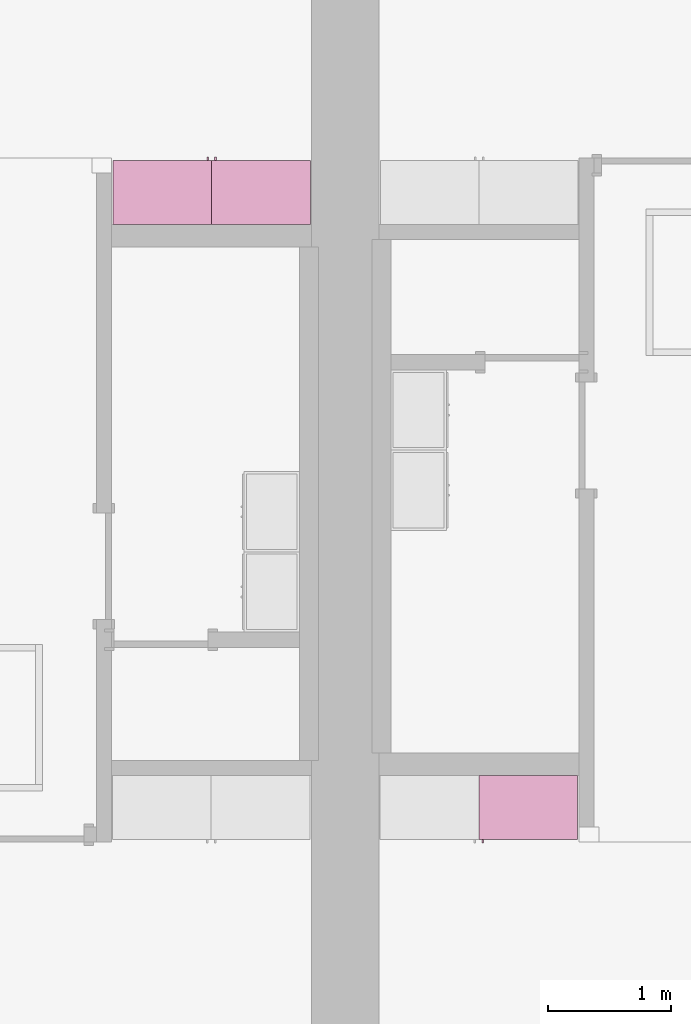
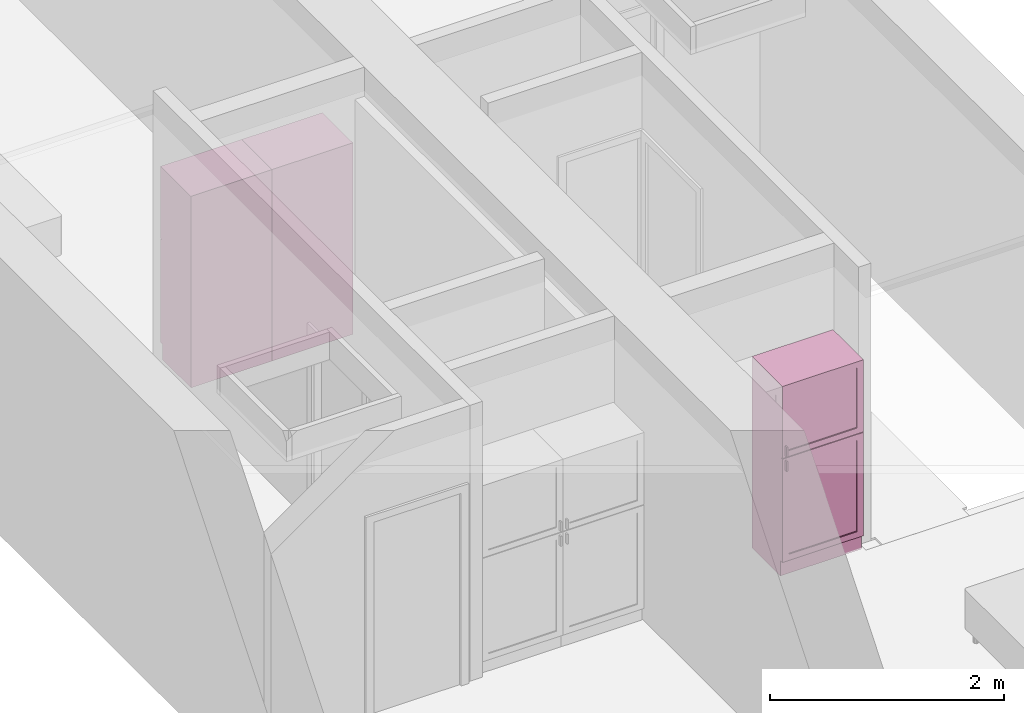
# One storey, part 15 of 16: 3 furnishings, 3 openings.
"""IFC2X3 building model written with IfcOpenShell, lengths in metres."""

from ifc_helpers import new_model, entity, si_unit, converted_unit, frame, origin, origin_2d_with_axis, place, context, project, spatial, rectangle, extrude, face_set, surface_model, source, transform, mapped, type_object, type_shapes, element, save


model = new_model("IFC2X3")

# Units and contexts
model_context = context("Model", 3, precision=1e-09, world=origin())
plan_context = context("Plan", 3, precision=1e-09, world=origin())
ifc_project = project(units=[si_unit("LENGTHUNIT", "METRE"), si_unit("AREAUNIT", "SQUARE_METRE"), si_unit("VOLUMEUNIT", "CUBIC_METRE"), converted_unit("PLANEANGLEUNIT", "DEGREE", entity("IfcRatioMeasure", 0.01745329251994328), si_unit("PLANEANGLEUNIT", "RADIAN"), dimensions=[0, 0, 0, 0, 0, 0, 0]), si_unit("TIMEUNIT", "SECOND")], contexts=[model_context, plan_context])

# Site, building, storey, space
site_placement = place(None, origin())
site = spatial("IfcSite", under=ifc_project, at=site_placement, CompositionType="ELEMENT")
building_placement = place(site_placement, origin())
building = spatial("IfcBuilding", under=site, at=building_placement, CompositionType="ELEMENT")
storey_placement = place(building_placement, frame((0.0, 0.0, 3.100000000000378)))
storey = spatial("IfcBuildingStorey", under=building, at=storey_placement, Name="Level 2", CompositionType="ELEMENT", Elevation=3.100000000000378)
space_1_placement = place(storey_placement, origin())
space_1 = spatial("IfcSpace", under=storey, at=space_1_placement, CompositionType="ELEMENT", InteriorOrExteriorSpace="INTERNAL")

# Furnishing, opening
furniture_type_1 = type_object("IfcFurnitureType", Name="800 mm", AssemblyPlace="NOTDEFINED")
shared_shape_1 = source(origin(), model_context, "Body", "SurfaceModel", [
    surface_model("IfcFaceBasedSurfaceModel", [(0.7999999999999998, 0.5009500000000022, 0.1615874999998423), (0.7999999999999998, 0.5009500000000022, 2.0), (0.0, 0.5009499999999997, 2.0), (0.0, 0.5009499999999997, 0.1615874999998423), (0.7809499999999974, 0.5009500000000022, 1.980949999999954), (0.7809499999999974, 0.5009500000000022, 0.1806374999998428), (0.01904999999999817, 0.5009499999999997, 0.1806374999998428), (0.01904999999999817, 0.5009499999999997, 1.980949999999954), (0.0, 0.0, 2.0), (0.0, 0.0, 0.0), (0.8000000000000026, 0.0, 0.0), (0.8000000000000014, 0.0, 2.0), (0.780949999999999, 0.0, 1.980949999999954), (0.780949999999999, 0.0, 0.1806374999998428), (0.0190499999999998, 0.0, 0.1806374999998427), (0.0190499999999998, 0.0, 1.980949999999954), (0.8000000000000026, 0.4850000000000004, 0.0), (0.7999999999999999, 0.4850000000000004, 0.1615874999998318), (0.0, 0.4850000000000004, 0.0), (0.0, 0.4850000000000004, 0.1615874999998423), (0.7745999999999997, 0.5454000000000022, 1.371548036695815), (0.7620677683693553, 0.5454000000000021, 1.371548036695815), (0.7620677683693553, 0.5454000000000021, 1.269948036695815), (0.7745999999999997, 0.5454000000000022, 1.269948036695815), (0.7745999999999988, 0.5454000000000022, 1.219148036695816), (0.7620677683693542, 0.5454000000000021, 1.219148036695816), (0.7620677683693542, 0.5454000000000021, 1.117548036695818), (0.7745999999999988, 0.5454000000000022, 1.117548036695818), (0.7745999999999998, 0.5200000000000022, 1.371548036695815), (0.7620677683693555, 0.5200000000000021, 1.371548036695815), (0.7620677683693555, 0.5200000000000021, 1.269948036695815), (0.7745999999999998, 0.5200000000000022, 1.269948036695815), (0.7745999999999988, 0.5200000000000022, 1.219148036695816), (0.7620677683693542, 0.5200000000000021, 1.219148036695816), (0.7620677683693542, 0.5200000000000021, 1.117548036695818), (0.7745999999999988, 0.5200000000000022, 1.117548036695818), (0.7364999999999996, 0.5073000000000021, 1.936499999999956), (0.06350000000000126, 0.5072999999999999, 1.936499999999956), (0.06350000000000126, 0.5072999999999999, 1.308048036695816), (0.7364999999999996, 0.5073000000000021, 1.308048036695816), (0.736499999999999, 0.5073000000000021, 1.181048036695814), (0.06350000000000072, 0.5072999999999999, 1.181048036695814), (0.06350000000000072, 0.5072999999999999, 0.2250874999998395), (0.736499999999999, 0.5073000000000021, 0.2250874999998395), (0.7364999999999996, 0.5009500000000021, 1.936499999999956), (0.06350000000000126, 0.5009499999999999, 1.936499999999956), (0.06350000000000126, 0.5009499999999999, 1.308048036695816), (0.7364999999999996, 0.5009500000000021, 1.308048036695816), (0.736499999999999, 0.5009500000000021, 1.181048036695814), (0.06350000000000072, 0.5009499999999999, 1.181048036695814), (0.06350000000000072, 0.5009499999999999, 0.2250874999998395), (0.736499999999999, 0.5009500000000021, 0.2250874999998395), (0.8, 0.5200000000000023, 2.0), (0.0, 0.5199999999999997, 2.0), (0.0, 0.5199999999999997, 1.247723036695813), (0.8, 0.5200000000000023, 1.247723036695813), (0.7364999999999996, 0.5200000000000021, 1.936499999999956), (0.7364999999999996, 0.5200000000000021, 1.308048036695816), (0.0635000000000012, 0.5199999999999999, 1.308048036695816), (0.0635000000000012, 0.5199999999999999, 1.936499999999956), (0.7999999999999998, 0.5200000000000023, 0.1615874999998214), (0.7999999999999998, 0.5200000000000023, 1.241373036695815), (0.0, 0.5199999999999997, 1.241373036695815), (0.0, 0.5199999999999997, 0.1615874999998214), (0.736499999999999, 0.5200000000000021, 1.181048036695817), (0.736499999999999, 0.5200000000000021, 0.2250874999998395), (0.06350000000000065, 0.5199999999999999, 0.2250874999998395), (0.06350000000000065, 0.5199999999999999, 1.181048036695817), (0.8000000000000002, 0.5009500000000023, 2.0), (0.0, 0.5009499999999997, 2.0), (0.0, 0.5009499999999997, 1.247723036695813), (0.8, 0.5009500000000023, 1.247723036695813), (0.7364999999999996, 0.5009500000000021, 1.936499999999956), (0.7364999999999996, 0.5009500000000021, 1.308048036695816), (0.06350000000000126, 0.5009499999999999, 1.308048036695816), (0.06350000000000126, 0.5009499999999999, 1.936499999999956), (0.7999999999999999, 0.5009500000000023, 0.1615874999998214), (0.7999999999999999, 0.5009500000000023, 1.241373036695815), (0.0, 0.5009499999999997, 1.241373036695815), (0.0, 0.5009499999999997, 0.1615874999998214), (0.736499999999999, 0.5009500000000021, 1.181048036695817), (0.736499999999999, 0.5009500000000021, 0.2250874999998395), (0.06350000000000072, 0.5009499999999999, 0.2250874999998395), (0.06350000000000072, 0.5009499999999999, 1.181048036695817), (0.7809499999999987, 0.01905000000000129, 1.980949999999952), (0.0190499999999998, 0.01905000000000129, 1.980949999999952), (0.0190499999999998, 0.01905000000000129, 0.1806374999998463), (0.7809499999999987, 0.01905000000000129, 0.1806374999998463), (0.7809499999999987, 0.0, 1.980949999999952), (0.0190499999999998, 0.0, 1.980949999999952), (0.01904999999999987, 0.0, 0.1806374999998463), (0.7809499999999988, 0.0, 0.1806374999998463)], [face_set([[[0, 1, 2, 3], [4, 5, 6, 7]], [[8, 9, 10, 11], [12, 13, 14, 15]], [[1, 11, 10, 16, 17, 0]], [[2, 1, 11, 8]], [[3, 2, 8, 9, 18, 19]], [[0, 17, 19, 3]], [[5, 4, 12, 13]], [[6, 5, 13, 14]], [[7, 6, 14, 15]], [[4, 12, 15, 7]], [[10, 9, 18, 16]], [[18, 16, 17, 19]]]), face_set([[[20, 21, 22, 23]], [[24, 25, 26, 27]], [[28, 29, 30, 31]], [[32, 33, 34, 35]], [[21, 20, 28, 29]], [[22, 30, 29, 21]], [[23, 31, 30, 22]], [[20, 23, 31, 28]], [[25, 24, 32, 33]], [[26, 34, 33, 25]], [[27, 35, 34, 26]], [[24, 27, 35, 32]]]), face_set([[[36, 37, 38, 39]], [[40, 41, 42, 43]], [[44, 45, 46, 47]], [[48, 49, 50, 51]], [[37, 36, 44, 45]], [[38, 37, 45, 46]], [[39, 47, 46, 38]], [[36, 44, 47, 39]], [[41, 40, 48, 49]], [[42, 41, 49, 50]], [[43, 51, 50, 42]], [[40, 48, 51, 43]]]), face_set([[[52, 53, 54, 55], [56, 57, 58, 59]], [[60, 61, 62, 63], [64, 65, 66, 67]], [[68, 69, 70, 71], [72, 73, 74, 75]], [[76, 77, 78, 79], [80, 81, 82, 83]], [[53, 52, 68, 69]], [[54, 70, 69, 53]], [[55, 71, 70, 54]], [[52, 68, 71, 55]], [[61, 77, 76, 60]], [[62, 61, 77, 78]], [[63, 79, 78, 62]], [[60, 76, 79, 63]], [[57, 56, 72, 73]], [[58, 57, 73, 74]], [[59, 75, 74, 58]], [[56, 72, 75, 59]], [[65, 64, 80, 81]], [[66, 65, 81, 82]], [[67, 83, 82, 66]], [[64, 80, 83, 67]]]), face_set([[[84, 85, 86, 87]], [[88, 89, 90, 91]], [[85, 84, 88, 89]], [[86, 90, 89, 85]], [[87, 91, 90, 86]], [[84, 88, 91, 87]]])]),
])
type_shapes(furniture_type_1, [shared_shape_1])
furnishing_1_placement = place(space_1_placement, frame((6.282999999999985, -11.13400000000001, 0.0), z_axis=(0.0, 0.0, 1.0), x_axis=(-1.0, 0.0, 0.0)))
furnishing_1 = element("IfcFurnishingElement", 1, at=furnishing_1_placement, inside=space_1, type_object=furniture_type_1, ObjectType="800 mm", context=model_context, shape_type="MappedRepresentation", body=[
    mapped(shared_shape_1, transform((0.0, 0.0, 0.0), scale=1.0)),
])
opening_1_placement = place(space_1_placement, frame((6.282999999999985, -11.13400000000001, 0.0), z_axis=(0.0, 0.0, 1.0), x_axis=(-1.0, 0.0, 0.0)))
element("IfcOpeningElement", 2, at=opening_1_placement, cuts=furnishing_1, ObjectType="Opening", context=model_context, shape_type="SweptSolid", body=[
    extrude(rectangle(XDim=1.800312500000111, YDim=0.7618999999999992, at=origin_2d_with_axis()), frame((-0.01873770491802511, 0.0, -2.01920625000048), z_axis=(0.0, -1.0, 0.0), x_axis=(0.0, 0.0, -1.0)), (0.0, 0.0, 1.0), 0.5009499999999997),
])

# Space
space_2_placement = place(storey_placement, origin())
space_2 = spatial("IfcSpace", under=storey, at=space_2_placement, CompositionType="ELEMENT", InteriorOrExteriorSpace="INTERNAL")

# Furnishing, opening
furniture_type_2 = type_object("IfcFurnitureType", Name="800 mm", AssemblyPlace="NOTDEFINED")
shared_shape_2 = source(origin(), model_context, "Body", "SurfaceModel", [
    surface_model("IfcFaceBasedSurfaceModel", [(0.7999999999999998, 0.04444999999999991, 0.1615874999998423), (0.0, 0.04445000000000255, 0.1615874999998423), (0.0, 0.04445000000000255, 2.0), (0.7999999999999998, 0.04444999999999991, 2.0), (0.7809499999999974, 0.04444999999999998, 1.980949999999954), (0.01904999999999817, 0.04445000000000248, 1.980949999999954), (0.01904999999999817, 0.04445000000000248, 0.1806374999998427), (0.7809499999999974, 0.04444999999999998, 0.1806374999998428), (0.0, 0.5454000000000022, 2.0), (0.8000000000000014, 0.5453999999999996, 2.0), (0.8000000000000026, 0.5453999999999996, 0.0), (0.0, 0.5454000000000009, 0.0), (0.780949999999999, 0.5453999999999996, 1.980949999999954), (0.0190499999999998, 0.5454000000000021, 1.980949999999954), (0.0190499999999998, 0.5454000000000021, 0.1806374999998428), (0.780949999999999, 0.5453999999999996, 0.1806374999998428), (0.7999999999999999, 0.06040000000000177, 0.1615874999998423), (0.7999999999999999, 0.06040000000000177, 0.0), (0.0, 0.06040000000000177, 0.0), (0.0, 0.06040000000000177, 0.1615874999998318), (0.7745999999999997, 0.0, 1.371548036695815), (0.7745999999999997, 0.0, 1.269948036695815), (0.7620677683693553, 0.0, 1.269948036695815), (0.7620677683693553, 0.0, 1.371548036695815), (0.7745999999999988, 0.0, 1.219148036695816), (0.7745999999999988, 0.0, 1.117548036695818), (0.7620677683693542, 0.0, 1.117548036695818), (0.7620677683693542, 0.0, 1.219148036695816), (0.7745999999999998, 0.02539999999999998, 1.371548036695815), (0.7745999999999998, 0.02539999999999998, 1.269948036695815), (0.7620677683693555, 0.02540000000000005, 1.269948036695815), (0.7620677683693555, 0.02540000000000005, 1.371548036695815), (0.7745999999999988, 0.02539999999999998, 1.219148036695816), (0.7745999999999988, 0.02539999999999998, 1.117548036695818), (0.7620677683693542, 0.02540000000000005, 1.117548036695818), (0.7620677683693542, 0.02540000000000005, 1.219148036695816), (0.7364999999999996, 0.03810000000000007, 1.936499999999956), (0.7364999999999996, 0.03810000000000007, 1.308048036695816), (0.06350000000000126, 0.03810000000000231, 1.308048036695816), (0.06350000000000126, 0.03810000000000231, 1.936499999999956), (0.736499999999999, 0.03810000000000007, 1.181048036695814), (0.736499999999999, 0.03810000000000007, 0.2250874999998395), (0.06350000000000072, 0.03810000000000231, 0.2250874999998395), (0.06350000000000072, 0.03810000000000231, 1.181048036695814), (0.7364999999999996, 0.04445000000000005, 1.936499999999956), (0.7364999999999996, 0.04445000000000005, 1.308048036695816), (0.06350000000000126, 0.04445000000000228, 1.308048036695816), (0.06350000000000126, 0.04445000000000228, 1.936499999999956), (0.736499999999999, 0.04445000000000005, 1.181048036695814), (0.736499999999999, 0.04445000000000005, 0.2250874999998395), (0.06350000000000072, 0.04445000000000228, 0.2250874999998395), (0.06350000000000072, 0.04445000000000228, 1.181048036695814), (0.8, 0.02539999999999984, 2.0), (0.8, 0.02539999999999984, 1.247723036695813), (0.0, 0.02540000000000248, 1.247723036695813), (0.0, 0.02540000000000248, 2.0), (0.7364999999999996, 0.02540000000000005, 1.936499999999956), (0.0635000000000012, 0.02540000000000228, 1.936499999999956), (0.0635000000000012, 0.02540000000000228, 1.308048036695816), (0.7364999999999996, 0.02540000000000005, 1.308048036695816), (0.7999999999999998, 0.02539999999999984, 0.1615874999998214), (0.0, 0.02540000000000248, 0.1615874999998214), (0.0, 0.02540000000000248, 1.241373036695815), (0.7999999999999998, 0.02539999999999984, 1.241373036695815), (0.736499999999999, 0.02540000000000005, 1.181048036695817), (0.06350000000000065, 0.02540000000000228, 1.181048036695817), (0.06350000000000065, 0.02540000000000228, 0.2250874999998395), (0.736499999999999, 0.02540000000000005, 0.2250874999998395), (0.8000000000000002, 0.04444999999999984, 2.0), (0.8000000000000002, 0.04444999999999984, 1.247723036695813), (0.0, 0.04445000000000248, 1.247723036695813), (0.0, 0.04445000000000248, 2.0), (0.7364999999999996, 0.04445000000000005, 1.936499999999956), (0.06350000000000126, 0.04445000000000228, 1.936499999999956), (0.06350000000000126, 0.04445000000000228, 1.308048036695816), (0.7364999999999996, 0.04445000000000005, 1.308048036695816), (0.7999999999999999, 0.04444999999999984, 0.1615874999998214), (0.0, 0.04445000000000248, 0.1615874999998214), (0.0, 0.04445000000000248, 1.241373036695815), (0.7999999999999999, 0.04444999999999984, 1.241373036695815), (0.736499999999999, 0.04445000000000005, 1.181048036695817), (0.06350000000000072, 0.04445000000000228, 1.181048036695817), (0.06350000000000072, 0.04445000000000228, 0.2250874999998395), (0.736499999999999, 0.04445000000000005, 0.2250874999998395), (0.7809499999999987, 0.5263500000000009, 1.980949999999952), (0.7809499999999988, 0.5263500000000009, 0.1806374999998463), (0.01904999999999987, 0.5263500000000009, 0.1806374999998463), (0.0190499999999998, 0.5263500000000009, 1.980949999999952), (0.7809499999999987, 0.5454000000000009, 1.980949999999952), (0.7809499999999987, 0.5454000000000009, 0.1806374999998463), (0.0190499999999998, 0.5454000000000009, 0.1806374999998463), (0.0190499999999998, 0.5454000000000009, 1.980949999999952)], [face_set([[[0, 1, 2, 3], [4, 5, 6, 7]], [[8, 9, 10, 11], [12, 13, 14, 15]], [[3, 0, 16, 17, 10, 9]], [[2, 8, 9, 3]], [[1, 2, 8, 11, 18, 19]], [[0, 1, 19, 16]], [[7, 15, 12, 4]], [[6, 14, 15, 7]], [[5, 13, 14, 6]], [[4, 5, 13, 12]], [[10, 17, 18, 11]], [[18, 19, 16, 17]]]), face_set([[[20, 21, 22, 23]], [[24, 25, 26, 27]], [[28, 29, 30, 31]], [[32, 33, 34, 35]], [[23, 31, 28, 20]], [[22, 23, 31, 30]], [[21, 22, 30, 29]], [[20, 28, 29, 21]], [[27, 35, 32, 24]], [[26, 27, 35, 34]], [[25, 26, 34, 33]], [[24, 32, 33, 25]]]), face_set([[[36, 37, 38, 39]], [[40, 41, 42, 43]], [[44, 45, 46, 47]], [[48, 49, 50, 51]], [[39, 47, 44, 36]], [[38, 46, 47, 39]], [[37, 38, 46, 45]], [[36, 37, 45, 44]], [[43, 51, 48, 40]], [[42, 50, 51, 43]], [[41, 42, 50, 49]], [[40, 41, 49, 48]]]), face_set([[[52, 53, 54, 55], [56, 57, 58, 59]], [[60, 61, 62, 63], [64, 65, 66, 67]], [[68, 69, 70, 71], [72, 73, 74, 75]], [[76, 77, 78, 79], [80, 81, 82, 83]], [[55, 71, 68, 52]], [[54, 55, 71, 70]], [[53, 54, 70, 69]], [[52, 53, 69, 68]], [[63, 60, 76, 79]], [[62, 78, 79, 63]], [[61, 62, 78, 77]], [[60, 61, 77, 76]], [[59, 75, 72, 56]], [[58, 74, 75, 59]], [[57, 58, 74, 73]], [[56, 57, 73, 72]], [[67, 83, 80, 64]], [[66, 82, 83, 67]], [[65, 66, 82, 81]], [[64, 65, 81, 80]]]), face_set([[[84, 85, 86, 87]], [[88, 89, 90, 91]], [[87, 91, 88, 84]], [[86, 87, 91, 90]], [[85, 86, 90, 89]], [[84, 85, 89, 88]]])]),
])
type_shapes(furniture_type_2, [shared_shape_2])
furnishing_2_placement = place(space_2_placement, frame((4.116999999999995, -6.120600000000001, 0.0), z_axis=(0.0, 0.0, 1.0), x_axis=(-1.0, 0.0, 0.0)))
furnishing_2 = element("IfcFurnishingElement", 3, at=furnishing_2_placement, inside=space_2, type_object=furniture_type_2, ObjectType="800 mm", context=model_context, shape_type="MappedRepresentation", body=[
    mapped(shared_shape_2, transform((0.0, 0.0, 0.0), scale=1.0)),
])
opening_2_placement = place(space_2_placement, frame((4.116999999999995, -6.120600000000001, 0.0), z_axis=(0.0, 0.0, 1.0), x_axis=(-1.0, 0.0, 0.0)))
element("IfcOpeningElement", 4, at=opening_2_placement, cuts=furnishing_2, ObjectType="Opening", context=model_context, shape_type="SweptSolid", body=[
    extrude(rectangle(XDim=1.800312500000111, YDim=0.7618999999999992, at=origin_2d_with_axis()), frame((-0.01873770491802666, 0.5009499999999996, -2.01920625000048), z_axis=(0.0, -1.0, 0.0), x_axis=(0.0, 0.0, -1.0)), (0.0, 0.0, 1.0), 0.5009499999999997),
])

furniture_type_3 = type_object("IfcFurnitureType", Name="800 mm", AssemblyPlace="NOTDEFINED")
shared_shape_3 = source(origin(), model_context, "Body", "SurfaceModel", [
    surface_model("IfcFaceBasedSurfaceModel", [(0.7999999999999998, 0.5009500000000022, 0.1615874999998423), (0.7999999999999998, 0.5009500000000022, 2.0), (0.0, 0.5009499999999997, 2.0), (0.0, 0.5009499999999997, 0.1615874999998423), (0.7809499999999974, 0.5009500000000022, 1.980949999999954), (0.7809499999999974, 0.5009500000000022, 0.1806374999998428), (0.01904999999999817, 0.5009499999999997, 0.1806374999998428), (0.01904999999999817, 0.5009499999999997, 1.980949999999954), (0.0, 0.0, 2.0), (0.0, 0.0, 0.0), (0.8000000000000026, 0.0, 0.0), (0.8000000000000014, 0.0, 2.0), (0.780949999999999, 0.0, 1.980949999999954), (0.780949999999999, 0.0, 0.1806374999998428), (0.0190499999999998, 0.0, 0.1806374999998427), (0.0190499999999998, 0.0, 1.980949999999954), (0.8000000000000026, 0.4850000000000004, 0.0), (0.7999999999999999, 0.4850000000000004, 0.1615874999998318), (0.0, 0.4850000000000004, 0.0), (0.0, 0.4850000000000004, 0.1615874999998423), (0.7745999999999997, 0.5454000000000022, 1.371548036695815), (0.7620677683693553, 0.5454000000000021, 1.371548036695815), (0.7620677683693553, 0.5454000000000021, 1.269948036695815), (0.7745999999999997, 0.5454000000000022, 1.269948036695815), (0.7745999999999988, 0.5454000000000022, 1.219148036695816), (0.7620677683693542, 0.5454000000000021, 1.219148036695816), (0.7620677683693542, 0.5454000000000021, 1.117548036695818), (0.7745999999999988, 0.5454000000000022, 1.117548036695818), (0.7745999999999998, 0.5200000000000022, 1.371548036695815), (0.7620677683693555, 0.5200000000000021, 1.371548036695815), (0.7620677683693555, 0.5200000000000021, 1.269948036695815), (0.7745999999999998, 0.5200000000000022, 1.269948036695815), (0.7745999999999988, 0.5200000000000022, 1.219148036695816), (0.7620677683693542, 0.5200000000000021, 1.219148036695816), (0.7620677683693542, 0.5200000000000021, 1.117548036695818), (0.7745999999999988, 0.5200000000000022, 1.117548036695818), (0.7364999999999996, 0.5073000000000021, 1.936499999999956), (0.06350000000000126, 0.5072999999999999, 1.936499999999956), (0.06350000000000126, 0.5072999999999999, 1.308048036695816), (0.7364999999999996, 0.5073000000000021, 1.308048036695816), (0.736499999999999, 0.5073000000000021, 1.181048036695814), (0.06350000000000072, 0.5072999999999999, 1.181048036695814), (0.06350000000000072, 0.5072999999999999, 0.2250874999998395), (0.736499999999999, 0.5073000000000021, 0.2250874999998395), (0.7364999999999996, 0.5009500000000021, 1.936499999999956), (0.06350000000000126, 0.5009499999999999, 1.936499999999956), (0.06350000000000126, 0.5009499999999999, 1.308048036695816), (0.7364999999999996, 0.5009500000000021, 1.308048036695816), (0.736499999999999, 0.5009500000000021, 1.181048036695814), (0.06350000000000072, 0.5009499999999999, 1.181048036695814), (0.06350000000000072, 0.5009499999999999, 0.2250874999998395), (0.736499999999999, 0.5009500000000021, 0.2250874999998395), (0.8, 0.5200000000000023, 2.0), (0.0, 0.5199999999999997, 2.0), (0.0, 0.5199999999999997, 1.247723036695813), (0.8, 0.5200000000000023, 1.247723036695813), (0.7364999999999996, 0.5200000000000021, 1.936499999999956), (0.7364999999999996, 0.5200000000000021, 1.308048036695816), (0.0635000000000012, 0.5199999999999999, 1.308048036695816), (0.0635000000000012, 0.5199999999999999, 1.936499999999956), (0.7999999999999998, 0.5200000000000023, 0.1615874999998214), (0.7999999999999998, 0.5200000000000023, 1.241373036695815), (0.0, 0.5199999999999997, 1.241373036695815), (0.0, 0.5199999999999997, 0.1615874999998214), (0.736499999999999, 0.5200000000000021, 1.181048036695817), (0.736499999999999, 0.5200000000000021, 0.2250874999998395), (0.06350000000000065, 0.5199999999999999, 0.2250874999998395), (0.06350000000000065, 0.5199999999999999, 1.181048036695817), (0.8000000000000002, 0.5009500000000023, 2.0), (0.0, 0.5009499999999997, 2.0), (0.0, 0.5009499999999997, 1.247723036695813), (0.8, 0.5009500000000023, 1.247723036695813), (0.7364999999999996, 0.5009500000000021, 1.936499999999956), (0.7364999999999996, 0.5009500000000021, 1.308048036695816), (0.06350000000000126, 0.5009499999999999, 1.308048036695816), (0.06350000000000126, 0.5009499999999999, 1.936499999999956), (0.7999999999999999, 0.5009500000000023, 0.1615874999998214), (0.7999999999999999, 0.5009500000000023, 1.241373036695815), (0.0, 0.5009499999999997, 1.241373036695815), (0.0, 0.5009499999999997, 0.1615874999998214), (0.736499999999999, 0.5009500000000021, 1.181048036695817), (0.736499999999999, 0.5009500000000021, 0.2250874999998395), (0.06350000000000072, 0.5009499999999999, 0.2250874999998395), (0.06350000000000072, 0.5009499999999999, 1.181048036695817), (0.7809499999999987, 0.01905000000000129, 1.980949999999952), (0.0190499999999998, 0.01905000000000129, 1.980949999999952), (0.0190499999999998, 0.01905000000000129, 0.1806374999998463), (0.7809499999999987, 0.01905000000000129, 0.1806374999998463), (0.7809499999999987, 0.0, 1.980949999999952), (0.0190499999999998, 0.0, 1.980949999999952), (0.01904999999999987, 0.0, 0.1806374999998463), (0.7809499999999988, 0.0, 0.1806374999998463)], [face_set([[[0, 1, 2, 3], [4, 5, 6, 7]], [[8, 9, 10, 11], [12, 13, 14, 15]], [[1, 11, 10, 16, 17, 0]], [[2, 1, 11, 8]], [[3, 2, 8, 9, 18, 19]], [[0, 17, 19, 3]], [[5, 4, 12, 13]], [[6, 5, 13, 14]], [[7, 6, 14, 15]], [[4, 12, 15, 7]], [[10, 9, 18, 16]], [[18, 16, 17, 19]]]), face_set([[[20, 21, 22, 23]], [[24, 25, 26, 27]], [[28, 29, 30, 31]], [[32, 33, 34, 35]], [[21, 20, 28, 29]], [[22, 30, 29, 21]], [[23, 31, 30, 22]], [[20, 23, 31, 28]], [[25, 24, 32, 33]], [[26, 34, 33, 25]], [[27, 35, 34, 26]], [[24, 27, 35, 32]]]), face_set([[[36, 37, 38, 39]], [[40, 41, 42, 43]], [[44, 45, 46, 47]], [[48, 49, 50, 51]], [[37, 36, 44, 45]], [[38, 37, 45, 46]], [[39, 47, 46, 38]], [[36, 44, 47, 39]], [[41, 40, 48, 49]], [[42, 41, 49, 50]], [[43, 51, 50, 42]], [[40, 48, 51, 43]]]), face_set([[[52, 53, 54, 55], [56, 57, 58, 59]], [[60, 61, 62, 63], [64, 65, 66, 67]], [[68, 69, 70, 71], [72, 73, 74, 75]], [[76, 77, 78, 79], [80, 81, 82, 83]], [[53, 52, 68, 69]], [[54, 70, 69, 53]], [[55, 71, 70, 54]], [[52, 68, 71, 55]], [[61, 77, 76, 60]], [[62, 61, 77, 78]], [[63, 79, 78, 62]], [[60, 76, 79, 63]], [[57, 56, 72, 73]], [[58, 57, 73, 74]], [[59, 75, 74, 58]], [[56, 72, 75, 59]], [[65, 64, 80, 81]], [[66, 65, 81, 82]], [[67, 83, 82, 66]], [[64, 80, 83, 67]]]), face_set([[[84, 85, 86, 87]], [[88, 89, 90, 91]], [[85, 84, 88, 89]], [[86, 90, 89, 85]], [[87, 91, 90, 86]], [[84, 88, 91, 87]]])]),
])
type_shapes(furniture_type_3, [shared_shape_3])
furnishing_3_placement = place(space_2_placement, frame((2.51699999999999, -6.665999999999991, 0.0)))
furnishing_3 = element("IfcFurnishingElement", 5, at=furnishing_3_placement, inside=space_2, type_object=furniture_type_3, ObjectType="800 mm", context=model_context, shape_type="MappedRepresentation", body=[
    mapped(shared_shape_3, transform((0.0, 0.0, 0.0), scale=1.0)),
])
opening_3_placement = place(space_2_placement, frame((2.51699999999999, -6.665999999999991, 0.0)))
element("IfcOpeningElement", 6, at=opening_3_placement, cuts=furnishing_3, ObjectType="Opening", context=model_context, shape_type="SweptSolid", body=[
    extrude(rectangle(XDim=1.800312500000111, YDim=0.7618999999999992, at=origin_2d_with_axis()), frame((0.01873770491802511, 0.0, -2.01920625000048), z_axis=(0.0, 1.0, 0.0), x_axis=(0.0, 0.0, -1.0)), (0.0, 0.0, 1.0), 0.5009499999999997),
])

save(model, "model.ifc")
